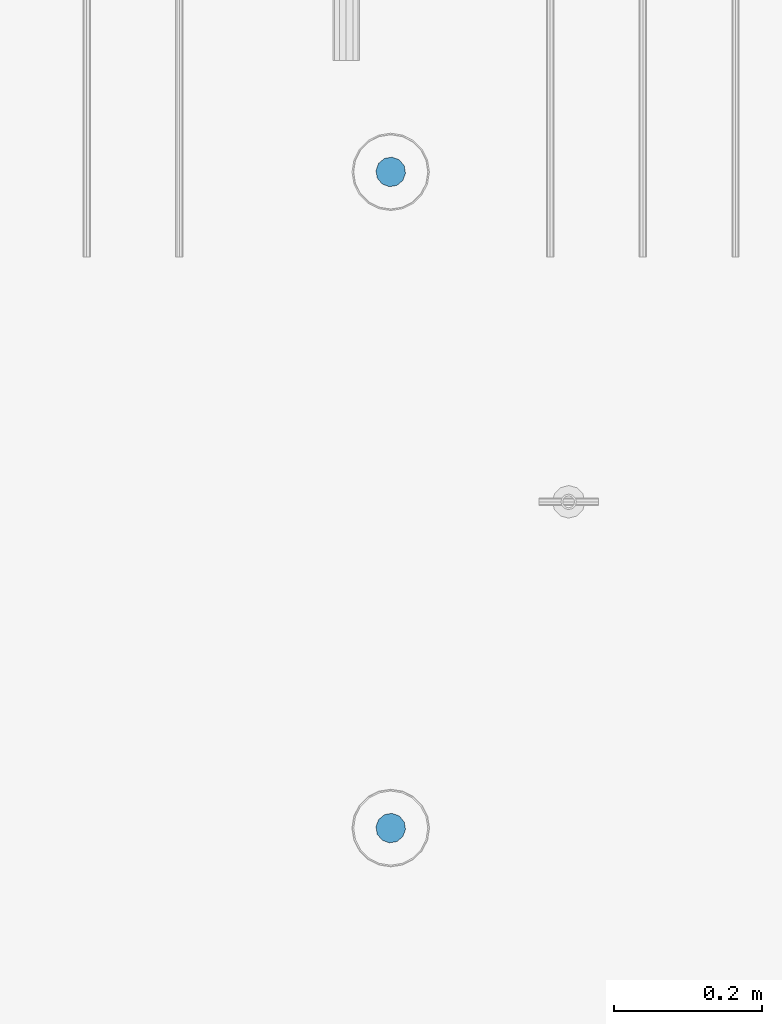
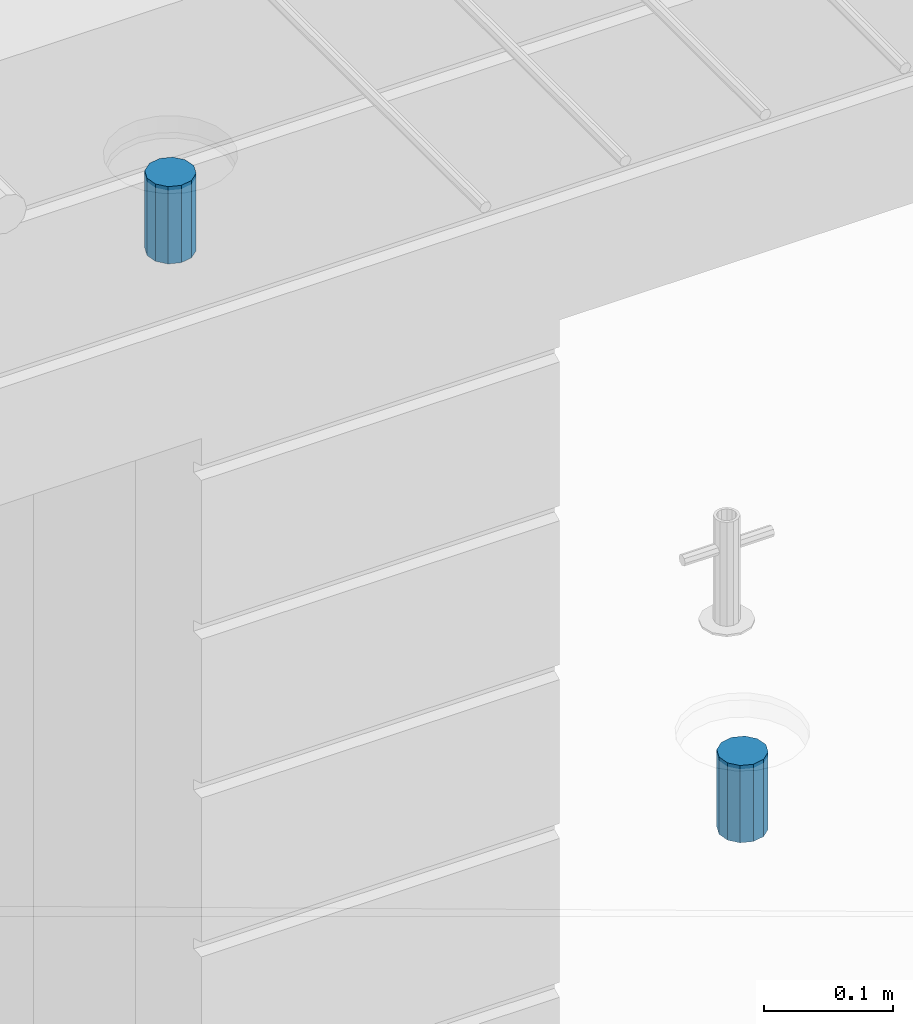
# One storey, part 46 of 350: 2 columns, 3 elements without a shape of their own.
"""IFC2X3 building model written with IfcOpenShell, lengths in millimetres."""

import ifcopenshell
import ifcopenshell.guid

model = None  # the IFC model being written
_history = None  # IfcOwnerHistory: only IFC2X3 demands one
_inside = {}  # id of a spatial element -> (the spatial element, [elements in it])
_under = {}  # id of a project, library or spatial element -> (it, [spatial elements below it])
_declared = {}  # id of a project -> (the project, [libraries it declares])
_typed = {}  # id of a type object -> (the type object, [elements of that type])
_made_of = {}  # id of a material, layer set ... -> (it, [elements and type objects made of it])


def new_model(schema):
    """Start an empty IFC model of exactly this schema.

    Asked for "IFC4X3", IfcOpenShell would pick the latest addendum, in which some entities
    have other attributes; the version numbers below select the first issue.
    IFC2X3 requires an IfcOwnerHistory on every rooted entity: one is made here for all.
    """
    global model, _history
    if schema == "IFC4X3":
        model = ifcopenshell.file(schema_version=(4, 3, 0, 0))
    else:
        model = ifcopenshell.file(schema=schema)
    _inside.clear()
    _under.clear()
    _declared.clear()
    _typed.clear()
    _made_of.clear()
    _history = None
    if model.schema == "IFC2X3":
        org = make("IfcOrganization", Name="unknown")
        user = make(
            "IfcPersonAndOrganization",
            ThePerson=make("IfcPerson", FamilyName="unknown"),
            TheOrganization=org,
        )
        app = make(
            "IfcApplication",
            ApplicationDeveloper=org,
            Version="unknown",
            ApplicationFullName="unknown",
            ApplicationIdentifier="unknown",
        )
        _history = make(
            "IfcOwnerHistory",
            OwningUser=user,
            OwningApplication=app,
            ChangeAction="ADDED",
            CreationDate=0,
        )
    return model


def make(cls, **values):
    """One entity of the class cls with the attributes given. An attribute that is None is left unset."""
    return model.create_entity(
        cls, **{name: value for name, value in values.items() if value is not None}
    )


def rooted(cls, **values):
    """An entity with a GlobalId (a new one), such as an element, a storey or a relation."""
    return make(cls, GlobalId=ifcopenshell.guid.new(), OwnerHistory=_history, **values)


def si_unit(unit_type, name, prefix=None):
    """IfcSIUnit, for example si_unit("LENGTHUNIT", "METRE", prefix="MILLI")."""
    return make("IfcSIUnit", UnitType=unit_type, Prefix=prefix, Name=name)


def assignment(units):
    """IfcUnitAssignment: the units of a project."""
    return None if units is None else make("IfcUnitAssignment", Units=units)


def point(xyz):
    """IfcCartesianPoint."""
    return None if xyz is None else make("IfcCartesianPoint", Coordinates=xyz)


def direction(xyz):
    """IfcDirection."""
    return None if xyz is None else make("IfcDirection", DirectionRatios=xyz)


def frame(location, z_axis=None, x_axis=None):
    """IfcAxis2Placement3D, a coordinate frame: its origin and axes. An axis left out is left unset."""
    return make(
        "IfcAxis2Placement3D",
        Location=point(location),
        Axis=direction(z_axis),
        RefDirection=direction(x_axis),
    )


def origin_with_axes():
    """The frame at (0, 0, 0) with the z axis (0, 0, 1) and the x axis (1, 0, 0) written out."""
    return frame((0.0, 0.0, 0.0), z_axis=(0.0, 0.0, 1.0), x_axis=(1.0, 0.0, 0.0))


def place(relative_to, where):
    """IfcLocalPlacement: puts the frame where relative to a parent placement (None: the world)."""
    return make(
        "IfcLocalPlacement", PlacementRelTo=relative_to, RelativePlacement=where
    )


def context(
    kind, dimensions, precision=None, world=None, true_north=None, identifier=None
):
    """IfcGeometricRepresentationContext, for example the 3D "Model" context."""
    return make(
        "IfcGeometricRepresentationContext",
        ContextIdentifier=identifier,
        ContextType=kind,
        CoordinateSpaceDimension=dimensions,
        Precision=precision,
        WorldCoordinateSystem=world,
        TrueNorth=true_north,
    )


def subcontext(parent, identifier, kind, view, scale=None):
    """IfcGeometricRepresentationSubContext, for example "Body" below "Model"."""
    return make(
        "IfcGeometricRepresentationSubContext",
        ContextIdentifier=identifier,
        ContextType=kind,
        ParentContext=parent,
        TargetScale=scale,
        TargetView=view,
    )


def project(units=None, contexts=None):
    """IfcProject with its units and contexts."""
    return rooted(
        "IfcProject",
        Name="project",
        RepresentationContexts=contexts,
        UnitsInContext=assignment(units),
    )


def spatial(cls, under=None, at=None, **own):
    """A site, building, storey or space (cls), placed at a placement, below another one or the project."""
    s = rooted(cls, ObjectPlacement=at, **own)
    if under is not None:
        _under.setdefault(under.id(), (under, []))[1].append(s)
    return s


def faces_of(points, faces, orient=None, outer=None):
    """IfcFace entities. A face is a list of loops; a loop is a list of indices into points, from 0.

    orient and outer hold one flag for each loop. By default every Orientation is true, the
    first loop of a face is its IfcFaceOuterBound and the others are IfcFaceBound.
    """
    made = []
    for i, loops in enumerate(faces):
        bounds = []
        for j, loop in enumerate(loops):
            is_outer = j == 0 if outer is None else outer[i][j]
            bounds.append(
                make(
                    "IfcFaceOuterBound" if is_outer else "IfcFaceBound",
                    Bound=make("IfcPolyLoop", Polygon=[points[k] for k in loop]),
                    Orientation=True if orient is None else orient[i][j],
                )
            )
        made.append(make("IfcFace", Bounds=bounds))
    return made


def faceted_brep(points, faces, orient=None, outer=None, voids=None):
    """IfcFacetedBrep: a solid bounded by flat faces; with voids (closed shells), ...WithVoids."""
    shared = [point(p) for p in points]
    hull = make("IfcClosedShell", CfsFaces=faces_of(shared, faces, orient, outer))
    if voids is None:
        return make("IfcFacetedBrep", Outer=hull)
    return make(
        "IfcFacetedBrepWithVoids",
        Outer=hull,
        Voids=[
            make(cls, CfsFaces=faces_of(shared, fs, o, b)) for cls, fs, o, b in voids
        ],
    )


def shape(context_of_items, identifier, shape_type, items):
    """IfcShapeRepresentation: the items that make up one representation, for example the "Body"."""
    return make(
        "IfcShapeRepresentation",
        ContextOfItems=context_of_items,
        RepresentationIdentifier=identifier,
        RepresentationType=shape_type,
        Items=items,
    )


def material(Name=None, Category=None):
    """IfcMaterial."""
    return make("IfcMaterial", Name=Name, Category=Category)


def made_of(thing, what):
    """Note that an element or type object is made of a material, layer set ...; save() writes the relation."""
    if what is not None:
        _made_of.setdefault(what.id(), (what, []))[1].append(thing)
    return thing


def type_object(cls, material=None, **own):
    """A type object (cls), such as IfcWallType, which elements share."""
    return made_of(rooted(cls, **own), material)


def element(
    cls,
    number,
    at=None,
    inside=None,
    cuts=None,
    type_object=None,
    material=None,
    context=None,
    identifier="Body",
    shape_type=None,
    held_by="IfcProductDefinitionShape",
    body=None,
    shapes=None,
    **own,
):
    """One element of the class cls, such as IfcWall. Its Tag is "e" and its number.

    at: its placement. inside: the storey or other place that contains it. cuts: it is an
    opening in that element (IfcRelVoidsElement). A single representation is given by context,
    identifier, shape_type and body (its items); several are given by shapes. held_by: the class
    of the entity that holds the representations. save() writes the other relations.
    """
    e = rooted(cls, Tag="e%d" % number, ObjectPlacement=at, **own)
    if body is not None:
        shapes = [shape(context, identifier, shape_type, body)]
    if shapes is not None:
        e.Representation = make(held_by, Representations=shapes)
    if inside is not None:
        _inside.setdefault(inside.id(), (inside, []))[1].append(e)
    if cuts is not None:
        rooted(
            "IfcRelVoidsElement", RelatingBuildingElement=cuts, RelatedOpeningElement=e
        )
    if type_object is not None:
        _typed.setdefault(type_object.id(), (type_object, []))[1].append(e)
    return made_of(e, material)


def aggregate(whole, parts):
    """IfcRelAggregates: a whole, such as a stair, and the parts it consists of."""
    return rooted("IfcRelAggregates", RelatingObject=whole, RelatedObjects=parts)


def save(model, path):
    """Write the relations noted so far, then the file.

    IfcRelAggregates (storeys below a building ...), IfcRelContainedInSpatialStructure (elements
    in a storey), IfcRelDefinesByType, IfcRelAssociatesMaterial and IfcRelDeclares: one each for
    every whole, place, type object, material and project.
    """
    for whole, parts in _under.values():
        aggregate(whole, parts)
    for where, things in _inside.values():
        rooted(
            "IfcRelContainedInSpatialStructure",
            RelatedElements=things,
            RelatingStructure=where,
        )
    for kind, things in _typed.values():
        rooted("IfcRelDefinesByType", RelatedObjects=things, RelatingType=kind)
    for what, things in _made_of.values():
        rooted("IfcRelAssociatesMaterial", RelatedObjects=things, RelatingMaterial=what)
    for by, libraries in _declared.values():
        rooted("IfcRelDeclares", RelatingContext=by, RelatedDefinitions=libraries)
    model.write(path)


model = new_model("IFC2X3")

# Units and contexts
model_context = context("Model", 3, precision=1e-05, world=origin_with_axes())
body_context = subcontext(model_context, "Body", "Model", "MODEL_VIEW")
ifc_project = project(units=[si_unit("LENGTHUNIT", "METRE", prefix="MILLI"), si_unit("AREAUNIT", "SQUARE_METRE"), si_unit("VOLUMEUNIT", "CUBIC_METRE"), si_unit("MASSUNIT", "GRAM", prefix="KILO"), si_unit("TIMEUNIT", "SECOND"), si_unit("PLANEANGLEUNIT", "RADIAN"), si_unit("SOLIDANGLEUNIT", "STERADIAN"), si_unit("THERMODYNAMICTEMPERATUREUNIT", "DEGREE_CELSIUS"), si_unit("LUMINOUSINTENSITYUNIT", "LUMEN")], contexts=[model_context])

# Site, building, storey
site_placement = place(None, origin_with_axes())
site = spatial("IfcSite", under=ifc_project, at=site_placement, CompositionType="ELEMENT")
building_placement = place(site_placement, origin_with_axes())
building = spatial("IfcBuilding", under=site, at=building_placement, CompositionType="ELEMENT")
storey_placement = place(building_placement, origin_with_axes())
storey = spatial("IfcBuildingStorey", under=building, at=storey_placement, Name="2", CompositionType="ELEMENT", Elevation=0.0)

# Assemblies, columns
assembly_1_placement = place(storey_placement, origin_with_axes())
assembly_1 = element("IfcElementAssembly", 1, at=assembly_1_placement, inside=storey, AssemblyPlace="NOTDEFINED", PredefinedType="REINFORCEMENT_UNIT")
assembly_2_placement = place(assembly_1_placement, origin_with_axes())
assembly_2 = element("IfcElementAssembly", 2, at=assembly_2_placement, Name="Steel Assembly", AssemblyPlace="NOTDEFINED", PredefinedType="RIGID_FRAME")
ifc_material = material(Name="STEEL/Steel_Undefined")
column_type = type_object("IfcColumnType", Name="D40", PredefinedType="NOTDEFINED")
column_1_placement = place(assembly_2_placement, frame((18019.9998566724, 6144.99747289933, 87625.0000000001), z_axis=(0.418944694779052, -0.908011752521126, 0.0), x_axis=(0.0, 0.0, 1.0)))
column_1 = element("IfcColumn", 3, at=column_1_placement, type_object=column_type, material=ifc_material, Name="R-Group R", ObjectType="D40", context=body_context, shape_type="Brep", body=[
    faceted_brep([(0.0, -20.0, 0.0), (0.0, -17.3205080756888, -10.0), (73.0, -17.3205080756852, -9.99999999999636), (73.0, -19.9999999999964, 3.63797880709171e-12), (0.0, -10.0, -17.3205080756888), (73.0, -10.0, -17.3205080756834), (0.0, 0.0, -20.0), (73.0, 3.63797880709171e-12, -19.9999999999964), (0.0, 10.0, -17.3205080756888), (73.0, 10.0000000000036, -17.3205080756834), (0.0, 17.3205080756888, -10.0), (73.0, 17.3205080756925, -9.99999999999818), (0.0, 20.0, 0.0), (73.0, 20.0, 3.63797880709171e-12), (0.0, 17.3205080756888, 10.0), (73.0, 17.3205080756888, 10.0000000000036), (0.0, 10.0, 17.3205080756888), (73.0, 10.0000000000036, 17.3205080756961), (0.0, 0.0, 20.0), (73.0, 3.63797880709171e-12, 20.0000000000036), (0.0, -10.0, 17.3205080756888), (73.0, -9.99999999999636, 17.3205080756925), (0.0, -17.3205080756888, 10.0), (73.0, -17.3205080756852, 10.0000000000055)], [[[0, 1, 2, 3]], [[1, 4, 5, 2]], [[4, 6, 7, 5]], [[6, 8, 9, 7]], [[8, 10, 11, 9]], [[10, 12, 13, 11]], [[12, 14, 15, 13]], [[14, 16, 17, 15]], [[16, 18, 19, 17]], [[18, 20, 21, 19]], [[20, 22, 23, 21]], [[22, 0, 3, 23]], [[5, 7, 9, 11, 13, 15, 17, 19, 21, 23, 3, 2]], [[22, 20, 18, 16, 14, 12, 10, 8, 6, 4, 1, 0]]]),
])
aggregate(assembly_2, [column_1])
assembly_3_placement = place(assembly_1_placement, origin_with_axes())
assembly_3 = element("IfcElementAssembly", 4, at=assembly_3_placement, Name="Steel Assembly", AssemblyPlace="NOTDEFINED", PredefinedType="RIGID_FRAME")
aggregate(assembly_1, [assembly_2, assembly_3])
column_2_placement = place(assembly_3_placement, frame((18019.9998566724, 7029.99747289932, 87635.0000000001), z_axis=(0.418944694779052, -0.908011752521126, 0.0), x_axis=(0.0, 0.0, 1.0)))
column_2 = element("IfcColumn", 5, at=column_2_placement, type_object=column_type, material=ifc_material, Name="R-Group R", ObjectType="D40", context=body_context, shape_type="Brep", body=[
    faceted_brep([(0.0, -20.0, 0.0), (0.0, -17.3205080756888, -10.0), (73.0, -17.3205080756852, -9.99999999999636), (73.0, -19.9999999999964, 3.63797880709171e-12), (0.0, -10.0, -17.3205080756888), (73.0, -10.0, -17.3205080756834), (0.0, 0.0, -20.0), (73.0, 3.63797880709171e-12, -19.9999999999964), (0.0, 10.0, -17.3205080756888), (73.0, 10.0000000000036, -17.3205080756834), (0.0, 17.3205080756888, -10.0), (73.0, 17.3205080756925, -9.99999999999818), (0.0, 20.0, 0.0), (73.0, 20.0, 3.63797880709171e-12), (0.0, 17.3205080756888, 10.0), (73.0, 17.3205080756888, 10.0000000000036), (0.0, 10.0, 17.3205080756888), (73.0, 10.0000000000036, 17.3205080756961), (0.0, 0.0, 20.0), (73.0, 3.63797880709171e-12, 20.0000000000036), (0.0, -10.0, 17.3205080756888), (73.0, -9.99999999999636, 17.3205080756925), (0.0, -17.3205080756888, 10.0), (73.0, -17.3205080756852, 10.0000000000055)], [[[0, 1, 2, 3]], [[1, 4, 5, 2]], [[4, 6, 7, 5]], [[6, 8, 9, 7]], [[8, 10, 11, 9]], [[10, 12, 13, 11]], [[12, 14, 15, 13]], [[14, 16, 17, 15]], [[16, 18, 19, 17]], [[18, 20, 21, 19]], [[20, 22, 23, 21]], [[22, 0, 3, 23]], [[5, 7, 9, 11, 13, 15, 17, 19, 21, 23, 3, 2]], [[22, 20, 18, 16, 14, 12, 10, 8, 6, 4, 1, 0]]]),
])
aggregate(assembly_3, [column_2])

save(model, "model.ifc")
